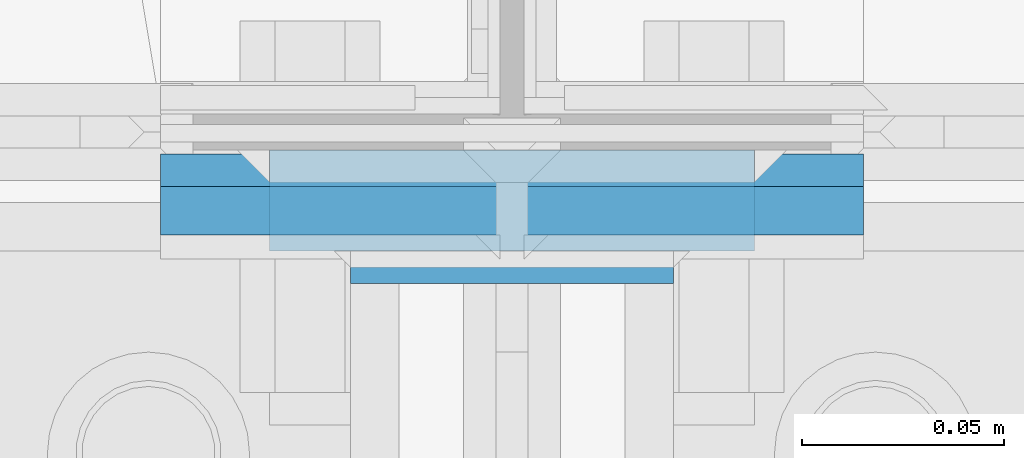
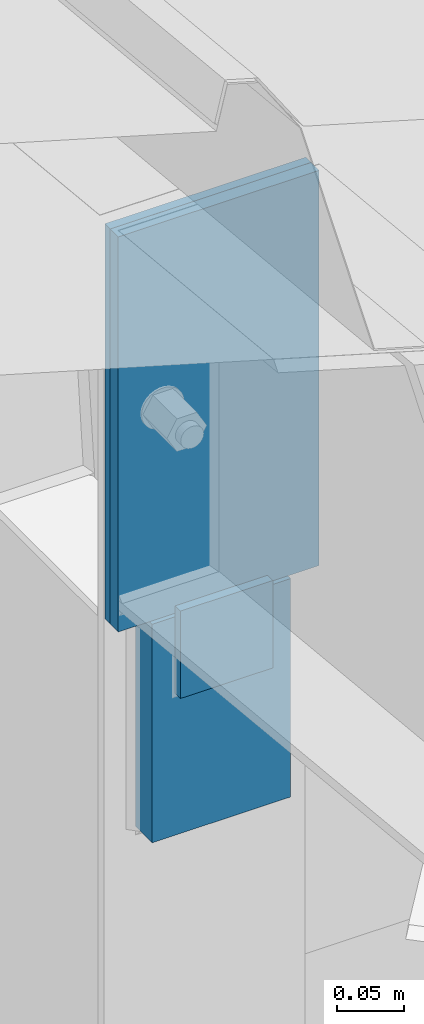
# One storey, part 27 of 709: 4 columns, 3 elements without a shape of their own.
"""IFC4 building model written with IfcOpenShell, lengths in millimetres."""

from ifc_helpers import new_model, si_unit, direction, frame, origin_with_axes, place, context, subcontext, project, spatial, line, indexed_curve, outline, extrude, material, element, aggregate, save


model = new_model("IFC4")

# Units and contexts
model_context = context("Model", 3, precision=0.2, world=origin_with_axes(), true_north=direction((0.0, 1.0)))
body_context = subcontext(model_context, "Body", "Model", "MODEL_VIEW")
ifc_project = project(units=[si_unit("LENGTHUNIT", "METRE", prefix="MILLI"), si_unit("AREAUNIT", "SQUARE_METRE"), si_unit("VOLUMEUNIT", "CUBIC_METRE"), si_unit("MASSUNIT", "GRAM", prefix="KILO"), si_unit("TIMEUNIT", "SECOND"), si_unit("PLANEANGLEUNIT", "RADIAN"), si_unit("SOLIDANGLEUNIT", "STERADIAN"), si_unit("THERMODYNAMICTEMPERATUREUNIT", "DEGREE_CELSIUS"), si_unit("LUMINOUSINTENSITYUNIT", "LUMEN")], contexts=[model_context])

# Site, building, storey
site_placement = place(None, origin_with_axes())
site = spatial("IfcSite", under=ifc_project, at=site_placement, CompositionType="ELEMENT")
building_placement = place(site_placement, origin_with_axes())
building = spatial("IfcBuilding", under=site, at=building_placement, Name="Undefined", CompositionType="ELEMENT")
storey_placement = place(building_placement, origin_with_axes())
storey = spatial("IfcBuildingStorey", under=building, at=storey_placement, Name="Undefined", CompositionType="ELEMENT", Elevation=0.0)

# Assembly, columns
assembly_1_placement = place(storey_placement, frame((46000.0, 21827.0, -200.0), z_axis=(-1.0, 0.0, 0.0), x_axis=(0.0, 0.0, 1.0)))
assembly_1 = element("IfcElementAssembly", 1, at=assembly_1_placement, inside=storey)
ifc_material = material(Name="C355-6", Category="STEEL")
column_1_placement = place(assembly_1_placement, frame((6897.93718, -185.5, 0.0), z_axis=(0.0, -1.0, 0.0), x_axis=(1.0, 0.0, 0.0)))
column_1 = element("IfcColumn", 2, at=column_1_placement, material=ifc_material, ObjectType="459", context=body_context, shape_type="SolidModel", body=[
    extrude(outline(indexed_curve([(-12.5, -60.0), (12.5, -60.0), (12.5, 60.0), (-12.5, 60.0)], segments=[line(1, 2, 3, 4, 1)])), frame((0.0, 0.0, 0.0), z_axis=(-1.0, 0.0, 0.0), x_axis=(0.0, 0.0, 1.0)), (0.0, 0.0, -1.0), 200.0),
])
column_2_placement = place(assembly_1_placement, frame((7027.93718, -202.0, 0.0), z_axis=(0.0, -1.0, 0.0), x_axis=(1.0, 0.0, 0.0)))
column_2 = element("IfcColumn", 3, at=column_2_placement, material=ifc_material, ObjectType="462", context=body_context, shape_type="SolidModel", body=[
    extrude(outline(indexed_curve([(-4.0, -40.0), (4.0, -40.0), (4.0, 40.0), (-4.0, 40.0)], segments=[line(1, 2, 3, 4, 1)])), frame((0.0, 0.0, 0.0), z_axis=(-1.0, 0.0, 0.0), x_axis=(0.0, 0.0, 1.0)), (0.0, 0.0, -1.0), 80.0),
])
aggregate(assembly_1, [column_1, column_2])

# Assembly, column
assembly_2_placement = place(storey_placement, frame((46000.0, 21654.0, 7089.70002), z_axis=(-1.0, 0.0, 0.0), x_axis=(0.0, -0.9950371902, 0.099503719)))
assembly_2 = element("IfcElementAssembly", 4, at=assembly_2_placement, inside=storey)
column_3_placement = place(assembly_2_placement, frame((-4.15556, -192.30372, 0.0), z_axis=(0.9950371902, -0.099503719, 0.0), x_axis=(0.099503719, 0.9950371902, 0.0)))
column_3 = element("IfcColumn", 5, at=column_3_placement, material=ifc_material, ObjectType="457", context=body_context, shape_type="SolidModel", body=[
    extrude(outline(indexed_curve([(-6.0, -87.0), (6.0, -87.0), (6.0, 87.0), (-6.0, 87.0)], segments=[line(1, 2, 3, 4, 1)])), frame((0.0, 0.0, 0.0), z_axis=(-1.0, 0.0, 0.0), x_axis=(0.0, 0.0, 1.0)), (0.0, 0.0, -1.0), 361.7257),
])
aggregate(assembly_2, [column_3])

assembly_3_placement = place(storey_placement, frame((46000.0, 21649.0, 6897.93718), z_axis=(0.0, -1.0, 0.0), x_axis=(0.0, 0.0, 1.0)))
assembly_3 = element("IfcElementAssembly", 6, at=assembly_3_placement, inside=storey)
column_4_placement = place(assembly_3_placement, origin_with_axes())
column_4 = element("IfcColumn", 7, at=column_4_placement, material=ifc_material, ObjectType="458", context=body_context, shape_type="SolidModel", body=[
    extrude(outline(indexed_curve([(-4.0, -87.0), (4.0, -87.0), (4.0, 87.0), (-4.0, 87.0)], segments=[line(1, 2, 3, 4, 1)])), frame((0.0, 0.0, 0.0), z_axis=(-1.0, 0.0, 0.0), x_axis=(0.0, 0.0, 1.0)), (0.0, 0.0, -1.0), 361.7257),
])
aggregate(assembly_3, [column_4])

save(model, "model.ifc")
